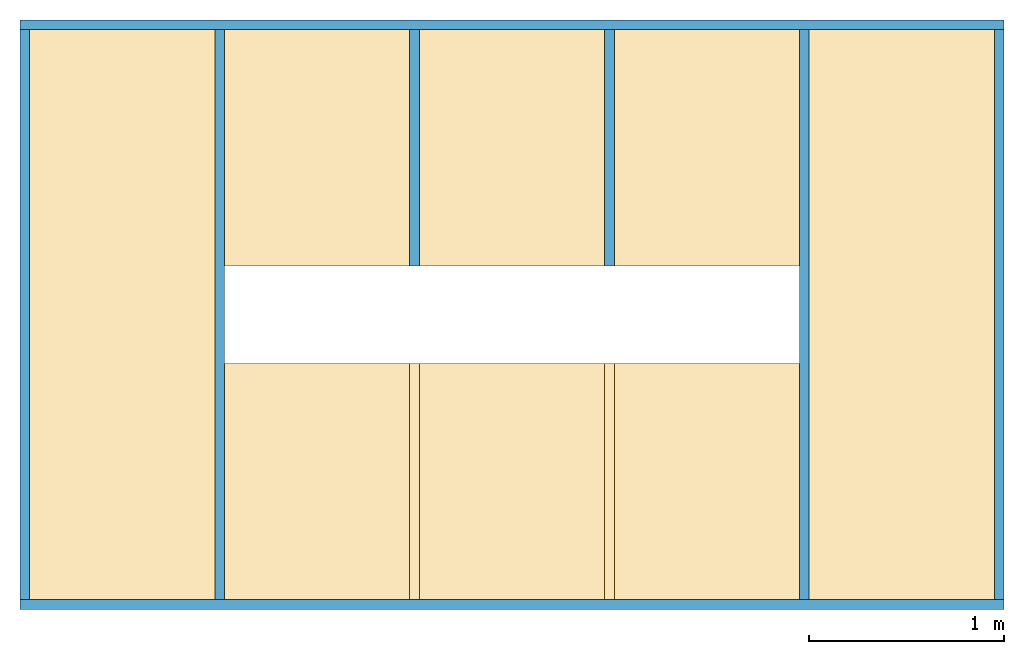
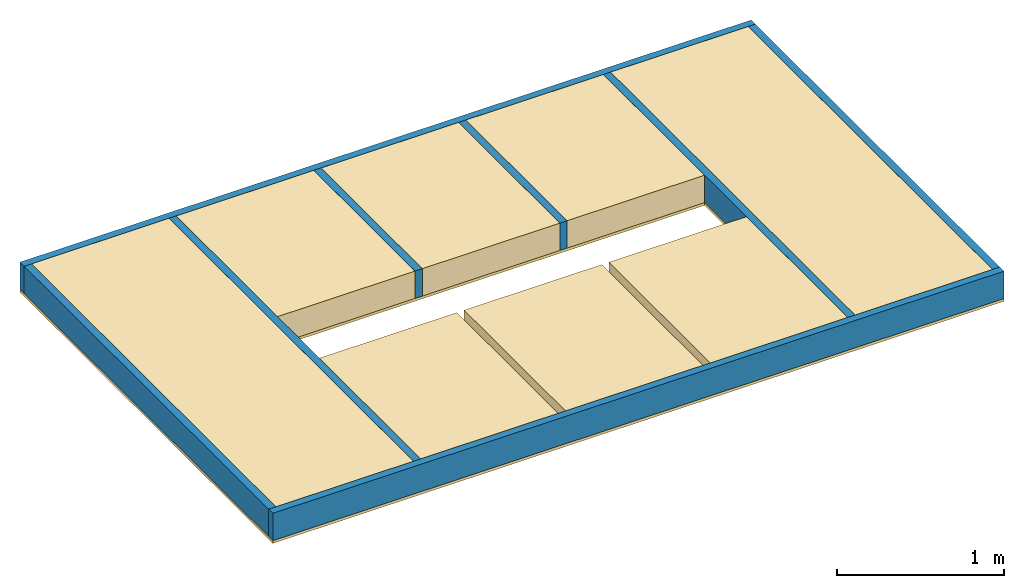
# One storey: 7 members, 6 coverings, 1 beam, 1 opening, 1 element without a shape of its own.
"""IFC4 building model written with IfcOpenShell, lengths in millimetres."""

from ifc_helpers import new_model, si_unit, frame, origin_with_axes, origin_2d_with_axis, place, context, subcontext, project, spatial, polyline, line, indexed_curve, rectangle, outline, extrude, element, aggregate, save


model = new_model("IFC4")

# Units and contexts
model_context_1 = context("Model", 3, precision=1e-05, world=origin_with_axes())
model_context_2 = context("Model", 3, precision=1e-05, world=origin_with_axes())
plan_context = context("Plan", 2, precision=1e-05, world=origin_2d_with_axis())
body_context_1 = subcontext(model_context_1, "Body", "Model", "MODEL_VIEW")
body_context_2 = subcontext(model_context_2, "Body", "Model", "MODEL_VIEW")
ifc_project = project(units=[si_unit("VOLUMEUNIT", "CUBIC_METRE"), si_unit("LENGTHUNIT", "METRE", prefix="MILLI"), si_unit("AREAUNIT", "SQUARE_METRE")], contexts=[model_context_1, model_context_2, plan_context])

# Site, building, storey
site = spatial("IfcSite", under=ifc_project)
building = spatial("IfcBuilding", under=site, Name="Building A")
storey = spatial("IfcBuildingStorey", under=building, Name="Ground Floor")

# Assembly, opening, members, beam, coverings
assembly_placement = place(None, origin_with_axes())
assembly = element("IfcElementAssembly", 1, at=assembly_placement, inside=storey, Name="Assembly")
opening_placement = place(assembly_placement, frame((2974.99990463257, 1487.49995231628, 100.000113248825), z_axis=(0.0, 0.0, 1.0), x_axis=(1.0, 0.0, 0.0)))
element("IfcOpeningElement", 2, at=opening_placement, cuts=assembly, Name="Opening", context=body_context_1, shape_type="SweptSolid", body=[
    extrude(outline(indexed_curve([(-1000.0, -249.999985098839), (1949.99992847443, -249.999985098839), (1949.99992847443, 249.999985098839), (-1000.0, 249.999985098839)], segments=[line(4, 1), line(1, 2), line(2, 3), line(3, 4)], self_intersect=False)), frame((0.0, 0.0, -249.999985098839), z_axis=(0.0, 0.0, -1.0), x_axis=(-1.0, 0.0, 0.0)), (0.0, 0.0, -1.0), 499.999970197677),
])
member_1_placement = place(assembly_placement, frame((0.0, 25.000000372529, 0.0), z_axis=(0.0, 1.0, 7.54979012640433e-08), x_axis=(1.0, 0.0, 0.0)))
member_1 = element("IfcMember", 3, at=member_1_placement, Name="my_beam", context=body_context_2, shape_type="SweptSolid", body=[
    extrude(rectangle(XDim=200.000007078051, YDim=50.0000017695129), frame((0.0, 0.0, 0.0), z_axis=(0.0, 0.0, -1.0), x_axis=(0.0, 1.0, 0.0)), (0.0, 0.0, -1.0), 2924.99999347915),
])
member_2_placement = place(assembly_placement, frame((1000.0, 25.000000372529, 0.0), z_axis=(0.0, 1.0, 7.54979012640433e-08), x_axis=(1.0, 0.0, 0.0)))
member_2 = element("IfcMember", 4, at=member_2_placement, Name="my_beam", context=body_context_2, shape_type="SweptSolid", body=[
    extrude(rectangle(XDim=200.000007078051, YDim=50.0000017695129), frame((0.0, 0.0, 0.0), z_axis=(0.0, 0.0, -1.0), x_axis=(0.0, 1.0, 0.0)), (0.0, 0.0, -1.0), 2924.99999347915),
])
member_3_placement = place(assembly_placement, frame((2000.0, 25.000000372529, 0.0), z_axis=(0.0, 1.0, 7.54979012640433e-08), x_axis=(1.0, 0.0, 0.0)))
member_3 = element("IfcMember", 5, at=member_3_placement, Name="my_beam", context=body_context_2, shape_type="SweptSolid", body=[
    extrude(rectangle(XDim=50.0000017695129, YDim=200.000007078051), frame((0.0, 0.0, 1712.49997615814), z_axis=(0.0, 0.0, -1.0), x_axis=(1.0, 0.0, 0.0)), (0.0, 0.0, -0.999999940395355), 1212.49997640393),
])
member_4_placement = place(assembly_placement, frame((3000.0, 25.000000372529, 0.0), z_axis=(0.0, 1.0, 7.54979012640433e-08), x_axis=(1.0, 0.0, 0.0)))
member_4 = element("IfcMember", 6, at=member_4_placement, Name="my_beam", context=body_context_2, shape_type="SweptSolid", body=[
    extrude(rectangle(XDim=50.0000017695129, YDim=200.000007078051), frame((0.0, 0.0, 1712.49997615814), z_axis=(0.0, 0.0, -1.0), x_axis=(1.0, 0.0, 0.0)), (0.0, 0.0, -0.999999940395355), 1212.49997640393),
])
member_5_placement = place(assembly_placement, frame((4000.0, 25.000000372529, 0.0), z_axis=(0.0, 1.0, 7.54979012640433e-08), x_axis=(1.0, 0.0, 0.0)))
member_5 = element("IfcMember", 7, at=member_5_placement, Name="my_beam", context=body_context_2, shape_type="SweptSolid", body=[
    extrude(rectangle(XDim=50.0000017695129, YDim=200.000007078051), frame((0.0, 0.0, 0.0), z_axis=(0.0, 0.0, -1.0), x_axis=(1.0, 0.0, 0.0)), (0.0, 0.0, -1.0), 2924.99999347915),
])
member_6_placement = place(assembly_placement, frame((5000.0, 25.000000372529, 0.0), z_axis=(0.0, 1.0, 7.54979012640433e-08), x_axis=(1.0, 0.0, 0.0)))
member_6 = element("IfcMember", 8, at=member_6_placement, Name="my_beam", context=body_context_2, shape_type="SweptSolid", body=[
    extrude(rectangle(XDim=200.000007078051, YDim=50.0000017695129), frame((0.0, 0.0, 0.0), z_axis=(0.0, 0.0, -1.0), x_axis=(0.0, 1.0, 0.0)), (0.0, 0.0, -1.0), 2924.99999347915),
])
member_7_placement = place(assembly_placement, frame((-25.000000372529, 0.0, 0.0), z_axis=(1.0, 4.37113882867379e-08, -4.37113882867379e-08), x_axis=(-4.37113882867379e-08, 1.0, 0.0)))
member_7 = element("IfcMember", 9, at=member_7_placement, Name="my_beam", context=body_context_2, shape_type="SweptSolid", body=[
    extrude(rectangle(XDim=200.000007078051, YDim=50.0000017695129), frame((0.0, 0.0, 0.0), z_axis=(0.0, 0.0, -1.0), x_axis=(0.0, 1.0, 0.0)), (0.0, 0.0, -0.999999940395355), 5050.00024172339),
])
beam_placement = place(assembly_placement, frame((-25.000000372529, 2974.99990463257, 0.0), z_axis=(1.0, 4.37113882867379e-08, -4.37113882867379e-08), x_axis=(-4.37113882867379e-08, 1.0, 0.0)))
beam = element("IfcBeam", 10, at=beam_placement, Name="my_beam", context=body_context_2, shape_type="SweptSolid", body=[
    extrude(rectangle(XDim=200.000007078051, YDim=50.0000017695129), frame((0.0, 0.0, 0.0), z_axis=(0.0, 0.0, -1.0), x_axis=(0.0, 1.0, 0.0)), (0.0, 0.0, -0.999999940395355), 5050.00024172339),
])
covering_1_placement = place(assembly_placement, frame((25.000000372529, 25.000000372529, 100.000001490116), z_axis=(0.0, 1.0, 7.54979012640433e-08), x_axis=(1.0, 0.0, 0.0)))
covering_1 = element("IfcCovering", 11, at=covering_1_placement, Name="insulation", context=body_context_1, shape_type="SweptSolid", body=[
    extrude(outline(polyline([(-474.999994039536, -100.000001490116), (474.999994039536, -100.000001490116), (474.999994039536, 100.000001490116), (-474.999994039536, 100.000001490116), (-474.999994039536, -100.000001490116)])), frame((474.999994039536, 100.000001490116, 0.0), z_axis=(0.0, 0.0, -1.0), x_axis=(-1.0, 0.0, 0.0)), (0.0, 0.0, -1.0), 2924.99999347915),
])
covering_2_placement = place(assembly_placement, frame((1024.99997615814, 25.000000372529, 100.000001490116), z_axis=(0.0, 1.0, 7.54979012640433e-08), x_axis=(1.0, 0.0, 0.0)))
covering_2 = element("IfcCovering", 12, at=covering_2_placement, Name="insulation", context=body_context_1, shape_type="SweptSolid", body=[
    extrude(outline(polyline([(-606.250047683716, -474.999994039536), (606.249928474426, -474.999994039536), (606.249928474426, 475.000023841858), (-606.250047683716, 474.999994039536), (-606.250047683716, -474.999994039536)]), holes=[polyline([(2318.74990463257, 475.00005364418), (1106.24992847443, 475.000023841858), (1106.24992847443, -474.999994039536), (2318.74990463257, -474.999934434891), (2318.74990463257, 475.00005364418)])]), frame((474.999994039536, 0.0, 2318.74990463257), z_axis=(0.0, -1.0, 0.0), x_axis=(-1.96633873628116e-08, 0.0, -0.999999940395355)), (-4.67005456528113e-08, 7.00507882811507e-08, -1.0), 200.000007078052),
])
covering_3_placement = place(assembly_placement, frame((2025.00009536743, 25.000000372529, 100.000001490116), z_axis=(0.0, 1.0, 7.54979012640433e-08), x_axis=(1.0, 0.0, 0.0)))
covering_3 = element("IfcCovering", 13, at=covering_3_placement, Name="insulation", context=body_context_1, shape_type="SweptSolid", body=[
    extrude(outline(polyline([(-474.999994039536, -606.249988079071), (474.999994039536, -606.249988079071), (474.999994039536, 606.249988079071), (-474.999994039536, 606.249988079071), (-474.999994039536, -606.249988079071)]), holes=[polyline([(474.999994039536, -1106.25004768372), (474.999994039536, -2318.74990463257), (-474.999994039536, -2318.74990463257), (-474.999994039536, -1106.25004768372), (474.999994039536, -1106.25004768372)])]), frame((474.999994039536, 0.0, 606.249988079071), z_axis=(0.0, -1.0, 0.0), x_axis=(-1.0, 0.0, 0.0)), (0.0, 0.0, -1.0), 200.000007078051),
])
covering_4_placement = place(assembly_placement, frame((3025.00009536743, 25.000000372529, 100.000001490116), z_axis=(0.0, 1.0, 7.54979012640433e-08), x_axis=(1.0, 0.0, 0.0)))
covering_4 = element("IfcCovering", 14, at=covering_4_placement, Name="insulation", context=body_context_1, shape_type="SweptSolid", body=[
    extrude(outline(polyline([(-475.000023841858, -606.249988079071), (474.999964237213, -606.249988079071), (474.999964237213, 606.249988079071), (-474.999964237213, 606.249988079071), (-475.000023841858, -606.249988079071)]), holes=[polyline([(-475.000023841858, 2318.74990463257), (-474.999964237213, 1106.25004768372), (474.999964237213, 1106.25004768372), (474.999964237213, 2318.74990463257), (-475.000023841858, 2318.74990463257)])]), frame((474.999964237213, 0.0, 606.249988079071), z_axis=(0.0, 1.0, 0.0), x_axis=(-1.0, 0.0, 0.0)), (0.0, 0.0, 1.0), 200.000007078051),
])
covering_5_placement = place(assembly_placement, frame((4025.00009536743, 25.000000372529, 100.000001490116), z_axis=(0.0, 1.0, 7.54979012640433e-08), x_axis=(1.0, 0.0, 0.0)))
covering_5 = element("IfcCovering", 15, at=covering_5_placement, Name="insulation", context=body_context_1, shape_type="SweptSolid", body=[
    extrude(outline(polyline([(-474.999994039536, -100.000001490116), (474.999994039536, -100.000001490116), (474.999994039536, 100.000001490116), (-474.999994039536, 100.000001490116), (-474.999994039536, -100.000001490116)])), frame((474.999994039536, 100.000001490116, 0.0), z_axis=(0.0, 0.0, -1.0), x_axis=(-1.0, 0.0, 0.0)), (0.0, 0.0, -1.0), 2924.99999347915),
])
covering_6_placement = place(assembly_placement, frame((-25.000000372529, -25.000000372529, -100.000001490116), z_axis=(0.0, 1.0, 7.54979012640433e-08), x_axis=(1.0, 0.0, 0.0)))
covering_6 = element("IfcCovering", 16, at=covering_6_placement, Name="insulation", context=body_context_1, shape_type="SweptSolid", body=[
    extrude(outline(polyline([(-2525.00009536743, -1512.50004768372), (2525.00009536743, -1512.50004768372), (2525.00009536743, 1512.50004768372), (-2525.00009536743, 1512.50004768372), (-2525.00009536743, -1512.50004768372)]), holes=[polyline([(1475.00014305115, 250.00011920929), (1475.00014305115, -249.99988079071), (-1474.99990463257, -249.99988079071), (-1474.99990463257, 250.00011920929), (1475.00014305115, 250.00011920929)])]), frame((2525.00009536743, 0.0, 1512.50004768372), z_axis=(0.0, -1.0, 0.0), x_axis=(-0.999999940395355, 0.0, 0.0)), (0.0, 0.0, -1.0), 19.9999997473787),
])
aggregate(assembly, [member_1, member_2, member_3, member_4, member_5, member_6, member_7, beam, covering_1, covering_2, covering_3, covering_4, covering_5, covering_6])

save(model, "model.ifc")
